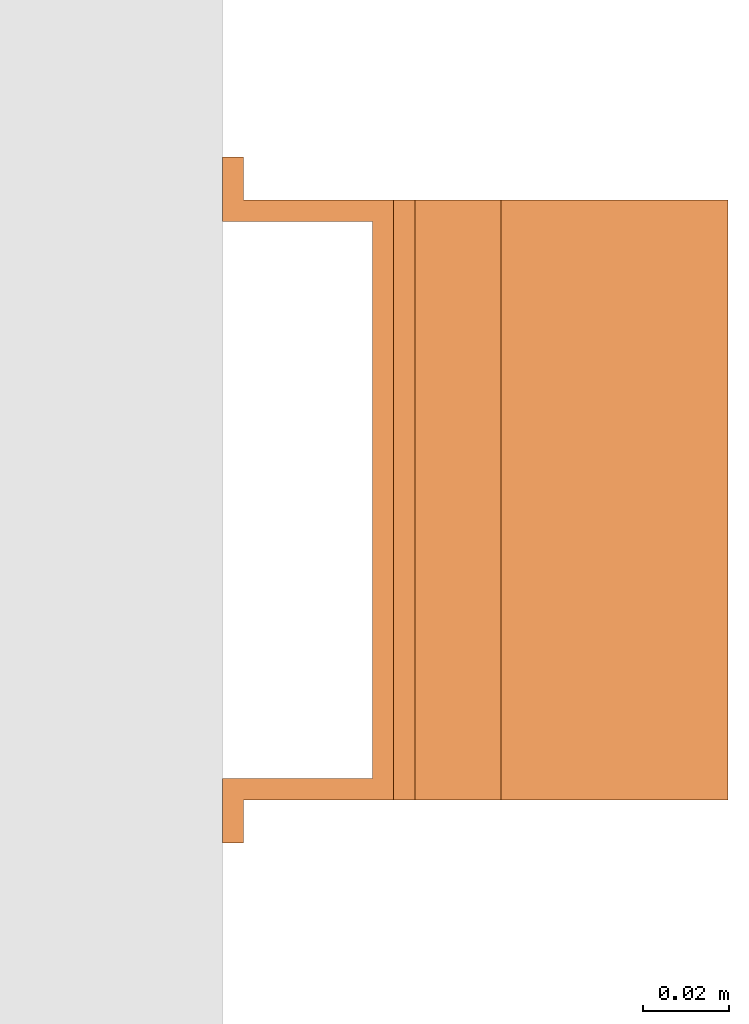
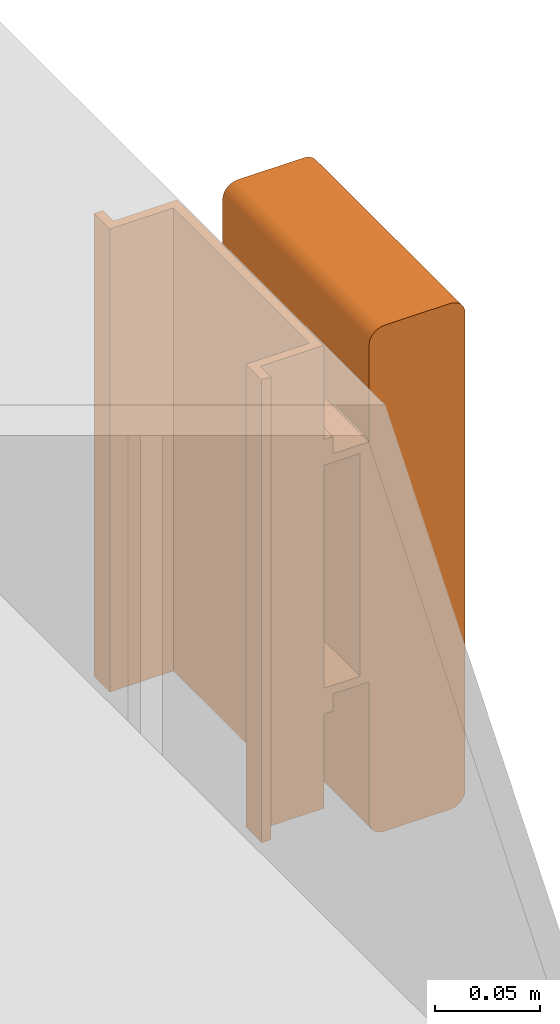
# One storey, part 9 of 9: 1 proxy.
"""IFC2X3 building model written with IfcOpenShell, lengths in millimetres."""

from ifc_helpers import new_model, entity, si_unit, converted_unit, derived_unit, direction, frame, frame_2d, origin, place, context, subcontext, project, spatial, polyline, circle_curve, parameter, trimmed, segment, composite_curve, outline, extrude, source, transform, mapped, material, material_list, type_object, type_shapes, element, save


model = new_model("IFC2X3")

# Units and contexts
model_context = context("Model", 3, precision=0.01, world=origin(), true_north=direction((6.12303176911189e-17, 1.0)))
body_context = subcontext(model_context, "Body", "Model", "MODEL_VIEW")
ifc_project = project(units=[si_unit("LENGTHUNIT", "METRE", prefix="MILLI"), si_unit("AREAUNIT", "SQUARE_METRE"), si_unit("VOLUMEUNIT", "CUBIC_METRE"), converted_unit("PLANEANGLEUNIT", "DEGREE", entity("IfcRatioMeasure", 0.0174532925199433), si_unit("PLANEANGLEUNIT", "RADIAN"), dimensions=[0, 0, 0, 0, 0, 0, 0]), si_unit("MASSUNIT", "GRAM", prefix="KILO"), derived_unit("MASSDENSITYUNIT", [(si_unit("MASSUNIT", "GRAM", prefix="KILO"), 1), (si_unit("LENGTHUNIT", "METRE"), -3)]), derived_unit("MOMENTOFINERTIAUNIT", [(si_unit("LENGTHUNIT", "METRE"), 4)]), si_unit("TIMEUNIT", "SECOND"), si_unit("FREQUENCYUNIT", "HERTZ"), si_unit("THERMODYNAMICTEMPERATUREUNIT", "DEGREE_CELSIUS"), derived_unit("THERMALTRANSMITTANCEUNIT", [(si_unit("MASSUNIT", "GRAM", prefix="KILO"), 1), (si_unit("THERMODYNAMICTEMPERATUREUNIT", "KELVIN"), -1), (si_unit("TIMEUNIT", "SECOND"), -3)]), derived_unit("VOLUMETRICFLOWRATEUNIT", [(si_unit("LENGTHUNIT", "METRE"), 3), (si_unit("TIMEUNIT", "SECOND"), -1)]), derived_unit("MASSFLOWRATEUNIT", [(si_unit("MASSUNIT", "GRAM", prefix="KILO"), 1), (si_unit("TIMEUNIT", "SECOND"), -1)]), derived_unit("ROTATIONALFREQUENCYUNIT", [(si_unit("TIMEUNIT", "SECOND"), -1)]), si_unit("ELECTRICCURRENTUNIT", "AMPERE"), si_unit("ELECTRICVOLTAGEUNIT", "VOLT"), si_unit("POWERUNIT", "WATT"), si_unit("FORCEUNIT", "NEWTON", prefix="KILO"), si_unit("ILLUMINANCEUNIT", "LUX"), si_unit("LUMINOUSFLUXUNIT", "LUMEN"), si_unit("LUMINOUSINTENSITYUNIT", "CANDELA"), derived_unit("USERDEFINED", [(si_unit("MASSUNIT", "GRAM", prefix="KILO"), -1), (si_unit("LENGTHUNIT", "METRE"), -2), (si_unit("TIMEUNIT", "SECOND"), 3), (si_unit("LUMINOUSFLUXUNIT", "LUMEN"), 1)]), derived_unit("LINEARVELOCITYUNIT", [(si_unit("LENGTHUNIT", "METRE"), 1), (si_unit("TIMEUNIT", "SECOND"), -1)]), si_unit("PRESSUREUNIT", "PASCAL"), derived_unit("USERDEFINED", [(si_unit("LENGTHUNIT", "METRE"), -2), (si_unit("MASSUNIT", "GRAM", prefix="KILO"), 1), (si_unit("TIMEUNIT", "SECOND"), -2)]), derived_unit("LINEARFORCEUNIT", [(si_unit("MASSUNIT", "GRAM", prefix="KILO"), 1), (si_unit("LENGTHUNIT", "METRE"), 1), (si_unit("TIMEUNIT", "SECOND"), -2), (si_unit("LENGTHUNIT", "METRE"), -1)]), derived_unit("PLANARFORCEUNIT", [(si_unit("MASSUNIT", "GRAM", prefix="KILO"), 1), (si_unit("LENGTHUNIT", "METRE"), 1), (si_unit("TIMEUNIT", "SECOND"), -2), (si_unit("LENGTHUNIT", "METRE"), -2)])], contexts=[model_context])

# Site, building, storey
site_placement = place(None, origin())
site = spatial("IfcSite", under=ifc_project, at=site_placement, CompositionType="ELEMENT")
building_placement = place(site_placement, origin())
building = spatial("IfcBuilding", under=site, at=building_placement, CompositionType="ELEMENT")
storey_placement = place(building_placement, frame((0.0, 0.0, 24000.0)))
storey = spatial("IfcBuildingStorey", under=building, at=storey_placement, CompositionType="ELEMENT", Elevation=24000.0)

# Proxy
ifc_material_1 = material()
ifc_material_2 = material()
ifc_material_list_1 = material_list([ifc_material_1, ifc_material_2])
ifc_material_list_2 = material_list([ifc_material_1, ifc_material_1, ifc_material_2])
building_element_proxy_type = type_object("IfcBuildingElementProxyType", PredefinedType="NOTDEFINED", material=ifc_material_list_2)
shared_shape = source(origin(), body_context, "Body", "SweptSolid", [
    extrude(outline(composite_curve([segment(polyline([(-18.16, -147.54), (18.05, -147.54)]), True, "CONTINUOUS"), segment(trimmed(circle_curve(frame_2d((18.05, -139.09), x_axis=(0.0, -1.0)), 8.44431603721898), [parameter(1.01777749806833e-13)], [parameter(90.0)], True, "PARAMETER"), True, "CONTINUOUS"), segment(polyline([(26.49, -139.09), (26.49, 139.31)]), True, "CONTINUOUS"), segment(trimmed(circle_curve(frame_2d((18.33, 139.31), x_axis=(0.0, -1.0)), 8.15582249386043), [parameter(90.0)], [parameter(180.0)], True, "PARAMETER"), True, "CONTINUOUS"), segment(polyline([(18.33, 147.46), (-18.18, 147.46)]), True, "CONTINUOUS"), segment(trimmed(circle_curve(frame_2d((-18.18, 139.13), x_axis=(0.0, -1.0)), 8.33189596389998), [parameter(180.0)], [parameter(270.0)], True, "PARAMETER"), True, "CONTINUOUS"), segment(polyline([(-26.51, 139.13), (-26.51, -139.19)]), True, "CONTINUOUS"), segment(trimmed(circle_curve(frame_2d((-18.16, -139.19), x_axis=(0.0, -1.0)), 8.35260143157827), [parameter(270.0)], [parameter(4.57999874130747e-13)], True, "PARAMETER"), True, "CONTINUOUS")], self_intersect=False)), frame((-70.0, 12.54, 91.49), z_axis=(1.0, 0.0, 0.0), x_axis=(0.0, 0.0, -1.0)), (0.0, 0.0, 1.0), 139.999999999992),
    extrude(outline(polyline([(-9.17, -80.0), (-4.17, -80.0), (-4.17, -70.0), (15.83, -70.0), (15.83, 70.0), (-4.17, 70.0), (-4.17, 80.0), (-9.17, 80.0), (-9.17, 65.0), (10.83, 65.0), (10.83, -65.0), (-9.17, -65.0), (-9.17, -80.0)])), frame((-70.0, 0.0, 49.17), z_axis=(1.0, 0.0, 0.0), x_axis=(0.0, 0.0, 1.0)), (0.0, 0.0, 1.0), 139.999999999992),
    extrude(outline(polyline([(-14.17, -80.0), (-9.17, -80.0), (-9.17, -70.0), (25.83, -70.0), (25.83, 70.0), (-9.17, 70.0), (-9.17, 80.0), (-14.17, 80.0), (-14.17, 65.0), (20.83, 65.0), (20.83, -65.0), (-14.17, -65.0), (-14.17, -80.0)])), frame((0.0, -135.0, 14.17), z_axis=(0.0, 1.0, 0.0), x_axis=(0.0, 0.0, 1.0)), (0.0, 0.0, 1.0), 270.0),
])
type_shapes(building_element_proxy_type, [shared_shape])
proxy_placement = place(storey_placement, frame((64156.88, 11662.79, 2919.6), z_axis=(1.0, 0.0, 0.0), x_axis=(0.0, -1.0, 0.0)))
element("IfcBuildingElementProxy", 1, at=proxy_placement, inside=storey, type_object=building_element_proxy_type, material=ifc_material_list_1, context=body_context, shape_type="MappedRepresentation", body=[
    mapped(shared_shape, transform((0.0, 0.0, 0.0), scale=1.0)),
])

save(model, "model.ifc")
